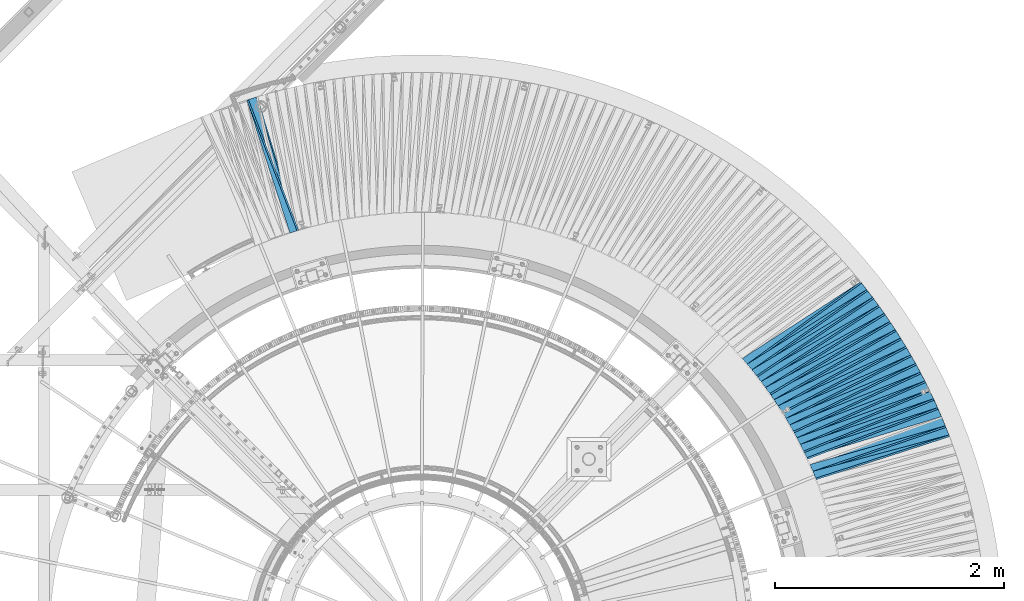
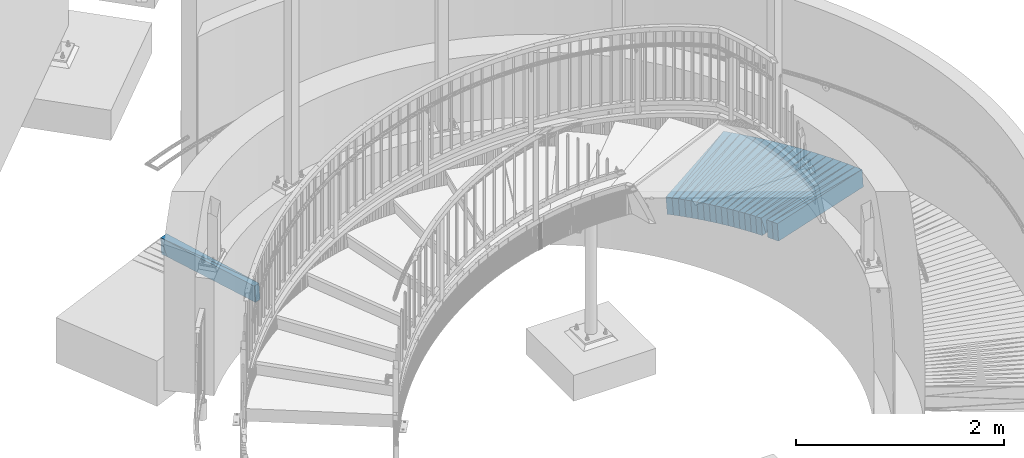
# One storey, part 836 of 975: 38 plates.
"""IFC2X3 building model written with IfcOpenShell, lengths in millimetres."""

from ifc_helpers import new_model, si_unit, frame, origin_with_axes, place, context, subcontext, project, spatial, faceted_brep, material, type_object, element, save


model = new_model("IFC2X3")

# Units and contexts
model_context = context("Model", 3, precision=1e-05, world=origin_with_axes())
body_context = subcontext(model_context, "Body", "Model", "MODEL_VIEW")
ifc_project = project(units=[si_unit("LENGTHUNIT", "METRE", prefix="MILLI"), si_unit("AREAUNIT", "SQUARE_METRE"), si_unit("VOLUMEUNIT", "CUBIC_METRE"), si_unit("MASSUNIT", "GRAM", prefix="KILO"), si_unit("TIMEUNIT", "SECOND"), si_unit("PLANEANGLEUNIT", "RADIAN"), si_unit("SOLIDANGLEUNIT", "STERADIAN"), si_unit("THERMODYNAMICTEMPERATUREUNIT", "DEGREE_CELSIUS"), si_unit("LUMINOUSINTENSITYUNIT", "LUMEN")], contexts=[model_context])

# Site, building, storey
site_placement = place(None, origin_with_axes())
site = spatial("IfcSite", under=ifc_project, at=site_placement, CompositionType="ELEMENT")
building_placement = place(site_placement, origin_with_axes())
building = spatial("IfcBuilding", under=site, at=building_placement, Name="Undefined", CompositionType="ELEMENT")
storey_placement = place(building_placement, origin_with_axes())
storey = spatial("IfcBuildingStorey", under=building, at=storey_placement, Name="Undefined", CompositionType="ELEMENT", Elevation=0.0)

# Plates
ifc_material = material(Name="STEEL/A36")
plate_type_1 = type_object("IfcPlateType", PredefinedType="NOTDEFINED")
plate_1_placement = place(storey_placement, frame((33217.5837224812, 8090.97640843276, -75.0314277608222), z_axis=(0.93169282219722, 0.358603764545342, 0.0578949490032381), x_axis=(0.358981557035001, -0.933335665091, 0.00409609300039937)))
element("IfcPlate", 1, at=plate_1_placement, inside=storey, type_object=plate_type_1, material=ifc_material, Name="SLAB", context=body_context, shape_type="Brep", body=[
    faceted_brep([(-6.82121026329696e-12, -100.000000000011, -1.09139364212751e-10), (4.55844306943254, -99.9999999999961, 86.0408096314204), (4.55844306940435, 99.9999999999868, 86.0408096311367), (5.91171556152403e-12, 100.000000000011, 1.09139364212751e-10), (1220.67553711095, -99.9999999998213, 1.37515598908067e-09), (1220.67553711092, 100.000000000162, 1.0986695997417e-09)], [[[0, 1, 2, 3]], [[1, 4, 5, 2]], [[4, 0, 3, 5]], [[5, 3, 2]], [[4, 1, 0]]]),
])
plate_2_placement = place(storey_placement, frame((39304.8373871946, 5243.97429969041, 351.684010269226), z_axis=(0.3241457711966, -0.944301974475064, 0.0567741139768603), x_axis=(-0.945743967281776, -0.324887014096797, -0.00409590300122032)))
element("IfcPlate", 2, at=plate_2_placement, inside=storey, type_object=plate_type_1, material=ifc_material, Name="SLAB", context=body_context, shape_type="Brep", body=[
    faceted_brep([(-6.82121026329696e-12, -100.000000000011, -1.09139364212751e-10), (-4.5795307158478, -100.000000000003, 85.9765548705582), (-4.57953071649536, 100.000000000011, 85.9765548707792), (5.91171556152403e-12, 100.000000000011, 1.09139364212751e-10), (1220.73205566726, -100.000000000089, 5.53882273379713e-10), (1220.73205566661, 99.9999999999249, 7.73070496506989e-10)], [[[0, 1, 2, 3]], [[1, 4, 5, 2]], [[4, 0, 3, 5]], [[5, 3, 2]], [[4, 1, 0]]]),
])
plate_3_placement = place(storey_placement, frame((39272.7669220496, 5323.70842472493, 346.690466458212), z_axis=(0.340651973808395, -0.938405020893698, 0.0578986139898226), x_axis=(-0.939893015923261, -0.341444550972121, -0.00409111599966596)))
element("IfcPlate", 3, at=plate_3_placement, inside=storey, type_object=plate_type_1, material=ifc_material, Name="SLAB", context=body_context, shape_type="Brep", body=[
    faceted_brep([(-6.82121026329696e-12, -100.000000000011, -1.09139364212751e-10), (-3.0377354618322, -100.00000000001, 86.1432037352588), (-3.03773546206503, 99.999999999996, 86.1432037352679), (5.91171556152403e-12, 100.000000000011, 1.09139364212751e-10), (1222.16040038976, -99.9999999999792, 4.68935468234122e-09), (1222.16040038953, 100.000000000026, 4.69844962935895e-09)], [[[0, 1, 2, 3]], [[1, 4, 5, 2]], [[4, 0, 3, 5]], [[5, 3, 2]], [[4, 1, 0]]]),
])
plate_4_placement = place(storey_placement, frame((39237.8605556861, 5402.24658344831, 341.690705146121), z_axis=(0.356899193856814, -0.932344350483872, 0.0579394299692631), x_axis=(-0.933820393213004, -0.357718742081596, -0.00409570300093424)))
element("IfcPlate", 4, at=plate_4_placement, inside=storey, type_object=plate_type_1, material=ifc_material, Name="SLAB", context=body_context, shape_type="Brep", body=[
    faceted_brep([(-6.82121026329696e-12, -100.000000000011, -1.09139364212751e-10), (-4.62327098886453, -99.999999999995, 85.9701995850792), (-4.62327098847163, 99.9999999999997, 85.9701995849482), (5.91171556152403e-12, 100.000000000011, 1.09139364212751e-10), (1220.79150390594, -100.00000000001, -2.37923813983798e-09), (1220.79150390635, 99.9999999999845, -2.51020537689328e-09)], [[[0, 1, 2, 3]], [[1, 4, 5, 2]], [[4, 0, 3, 5]], [[5, 3, 2]], [[4, 1, 0]]]),
])
plate_5_placement = place(storey_placement, frame((39202.9509047496, 5480.89350006488, 336.69050436779), z_axis=(0.373208382774436, -0.925938713118775, 0.0579051170004576), x_axis=(-0.927398456102163, -0.374052620041207, -0.00409158400045077)))
element("IfcPlate", 5, at=plate_5_placement, inside=storey, type_object=plate_type_1, material=ifc_material, Name="SLAB", context=body_context, shape_type="Brep", body=[
    faceted_brep([(-6.82121026329696e-12, -100.000000000011, -1.09139364212751e-10), (-3.07886791213241, -100.000000000005, 86.1305999755368), (-3.07886791187047, 99.999999999986, 86.1305999753968), (5.91171556152403e-12, 100.000000000011, 1.09139364212751e-10), (1222.02062988063, -99.9999999999855, 4.49108483735472e-09), (1222.02062988089, 100.000000000005, 4.34920366387814e-09)], [[[0, 1, 2, 3]], [[1, 4, 5, 2]], [[4, 0, 3, 5]], [[5, 3, 2]], [[4, 1, 0]]]),
])
plate_6_placement = place(storey_placement, frame((39165.3340698163, 5558.23520251872, 331.690488223701), z_axis=(0.389230944334602, -0.919318205497274, 0.0579077629827445), x_axis=(-0.920765250109163, -0.390096452046248, -0.00401401200047588)))
element("IfcPlate", 6, at=plate_6_placement, inside=storey, type_object=plate_type_1, material=ifc_material, Name="SLAB", context=body_context, shape_type="Brep", body=[
    faceted_brep([(-6.82121026329696e-12, -100.000000000011, -1.09139364212751e-10), (-4.57846403087751, -100.000000000012, 86.0268402097481), (-4.57846403123403, 100.000000000002, 86.02684020997), (5.91171556152403e-12, 100.000000000011, 1.09139364212751e-10), (1220.72375487936, -100.000000000106, -4.74756234325469e-10), (1220.72375487992, 99.9999999999141, -2.58296495303512e-10)], [[[0, 1, 2, 3]], [[1, 4, 5, 2]], [[4, 0, 3, 5]], [[5, 3, 2]], [[4, 1, 0]]]),
])
plate_7_placement = place(storey_placement, frame((39127.6781242042, 5635.68542388389, 326.783982722012), z_axis=(0.405335962729113, -0.912403040192737, 0.0567754310024517), x_axis=(-0.913777206059758, -0.406195939026564, -0.00400958900026222)))
element("IfcPlate", 7, at=plate_7_placement, inside=storey, type_object=plate_type_1, material=ifc_material, Name="SLAB", context=body_context, shape_type="Brep", body=[
    faceted_brep([(-6.82121026329696e-12, -100.000000000011, -1.09139364212751e-10), (-3.0701014992228, -100.000000000012, 86.0881195066431), (-3.07010149981943, 100.000000000009, 86.0881195069851), (5.91171556152403e-12, 100.000000000011, 1.09139364212751e-10), (1222.07031249683, -99.9999999999339, 5.11863618157804e-09), (1222.07031249622, 100.000000000087, 5.46424416825175e-09)], [[[0, 1, 2, 3]], [[1, 4, 5, 2]], [[4, 0, 3, 5]], [[5, 3, 2]], [[4, 1, 0]]]),
])
plate_8_placement = place(storey_placement, frame((39087.3718832034, 5711.6376815379, 321.883919295592), z_axis=(0.421079361007695, -0.905246203413047, 0.0567581090207884), x_axis=(-0.906602014252512, -0.421966836117529, -0.00409597000114084)))
element("IfcPlate", 8, at=plate_8_placement, inside=storey, type_object=plate_type_1, material=ifc_material, Name="SLAB", context=body_context, shape_type="Brep", body=[
    faceted_brep([(-6.82121026329696e-12, -100.000000000011, -1.09139364212751e-10), (-4.61950874349714, -99.9999999999928, 85.9979095460239), (-4.61950874354079, 100.000000000009, 85.9979095460349), (5.91171556152403e-12, 100.000000000011, 1.09139364212751e-10), (1220.71203612899, -99.9999999999177, -1.30785338114947e-09), (1220.71203612895, 100.000000000084, -1.2933014659211e-09)], [[[0, 1, 2, 3]], [[1, 4, 5, 2]], [[4, 0, 3, 5]], [[5, 3, 2]], [[4, 1, 0]]]),
])
plate_9_placement = place(storey_placement, frame((39047.2043368009, 5787.47328674119, 316.89090520201), z_axis=(0.43684924137823, -0.897664230680591, 0.0579799039658314), x_axis=(-0.899067716379963, -0.43779123318502, -0.00400967700169456)))
element("IfcPlate", 9, at=plate_9_placement, inside=storey, type_object=plate_type_1, material=ifc_material, Name="SLAB", context=body_context, shape_type="Brep", body=[
    faceted_brep([(-6.82121026329696e-12, -100.000000000011, -1.09139364212751e-10), (-3.02412271469802, -100.000000000008, 86.0276412962248), (-3.02412271522917, 100.000000000009, 86.0276412965322), (5.91171556152403e-12, 100.000000000011, 1.09139364212751e-10), (1222.04370117421, -100.000000000086, -3.67253960575908e-09), (1222.04370117367, 99.9999999999309, -3.36331140715629e-09)], [[[0, 1, 2, 3]], [[1, 4, 5, 2]], [[4, 0, 3, 5]], [[5, 3, 2]], [[4, 1, 0]]]),
])
plate_10_placement = place(storey_placement, frame((39004.2425576214, 5862.13925037848, 311.983785554002), z_axis=(0.452393196076373, -0.890012124948215, 0.0567345889997196), x_axis=(-0.891335017694484, -0.453326714844618, -0.0040958319985961)))
element("IfcPlate", 10, at=plate_10_placement, inside=storey, type_object=plate_type_1, material=ifc_material, Name="SLAB", context=body_context, shape_type="Brep", body=[
    faceted_brep([(-6.82121026329696e-12, -100.000000000011, -1.09139364212751e-10), (-4.57463502939936, -99.9999999999849, 86.0368118288479), (-4.5746350287518, 99.9999999999941, 86.036811828586), (5.91171556152403e-12, 100.000000000011, 1.09139364212751e-10), (1220.75317382871, -100.000000000028, -5.38420863449574e-10), (1220.75317382935, 99.9999999999507, -7.98536348156631e-10)], [[[0, 1, 2, 3]], [[1, 4, 5, 2]], [[4, 0, 3, 5]], [[5, 3, 2]], [[4, 1, 0]]]),
])
plate_11_placement = place(storey_placement, frame((38961.3826333786, 5936.58654527266, 306.99058968587), z_axis=(0.467883524941811, -0.881890185730348, 0.0579198359849058), x_axis=(-0.883254491691378, -0.468876063836167, -0.00409141399857039)))
element("IfcPlate", 11, at=plate_11_placement, inside=storey, type_object=plate_type_1, material=ifc_material, Name="SLAB", context=body_context, shape_type="Brep", body=[
    faceted_brep([(-6.82121026329696e-12, -100.000000000011, -1.09139364212751e-10), (-3.06913352011179, -100.000000000001, 86.1094131469526), (-3.06913352039555, 100.000000000005, 86.1094131471145), (5.91171556152403e-12, 100.000000000011, 1.09139364212751e-10), (1222.07128906666, -100.000000000093, -1.39516487251967e-09), (1222.07128906639, 99.9999999999133, -1.23509380500764e-09)], [[[0, 1, 2, 3]], [[1, 4, 5, 2]], [[4, 0, 3, 5]], [[5, 3, 2]], [[4, 1, 0]]]),
])
plate_12_placement = place(storey_placement, frame((38915.861182674, 6009.53732260342, 301.990549499056), z_axis=(0.48319325767782, -0.873595868993539, 0.0579183339895024), x_axis=(-0.874945036402083, -0.484205609222519, -0.00401388500184458)))
element("IfcPlate", 12, at=plate_12_placement, inside=storey, type_object=plate_type_1, material=ifc_material, Name="SLAB", context=body_context, shape_type="Brep", body=[
    faceted_brep([(-6.82121026329696e-12, -100.000000000011, -1.09139364212751e-10), (-4.61897420861351, -100.000000000009, 86.0083465574935), (-4.61897420915921, 100.000000000007, 86.0083465577081), (5.91171556152403e-12, 100.000000000011, 1.09139364212751e-10), (1220.76245117532, -100.000000000111, -3.84352460969239e-09), (1220.76245117479, 99.9999999999047, -3.62524588126689e-09)], [[[0, 1, 2, 3]], [[1, 4, 5, 2]], [[4, 0, 3, 5]], [[5, 3, 2]], [[4, 1, 0]]]),
])
plate_13_placement = place(storey_placement, frame((38870.2934492541, 6082.7004527467, 297.083744262738), z_axis=(0.498478531507273, -0.865044003722468, 0.0567276409711753), x_axis=(-0.866315894896196, -0.49947975994015, -0.00409141299950977)))
element("IfcPlate", 13, at=plate_13_placement, inside=storey, type_object=plate_type_1, material=ifc_material, Name="SLAB", context=body_context, shape_type="Brep", body=[
    faceted_brep([(-6.82121026329696e-12, -100.000000000011, -1.09139364212751e-10), (-3.06203031529003, -100.000000000005, 86.1567993163808), (-3.06203031592304, 100.00000000002, 86.15679931671), (5.91171556152403e-12, 100.000000000011, 1.09139364212751e-10), (1222.07153320566, -99.9999999999113, -3.09228198602796e-10), (1222.07153320539, 100.000000000073, -4.69299266114831e-10)], [[[0, 1, 2, 3]], [[1, 4, 5, 2]], [[4, 0, 3, 5]], [[5, 3, 2]], [[4, 1, 0]]]),
])
plate_14_placement = place(storey_placement, frame((38822.3382766663, 6153.85139697975, 292.090799755722), z_axis=(0.513379285667194, -0.8562025717769, 0.0579557169782551), x_axis=(-0.857514643792092, -0.514443251875272, -0.00409588599900694)))
element("IfcPlate", 14, at=plate_14_placement, inside=storey, type_object=plate_type_1, material=ifc_material, Name="SLAB", context=body_context, shape_type="Brep", body=[
    faceted_brep([(-6.82121026329696e-12, -100.000000000011, -1.09139364212751e-10), (-4.63857412335346, -100.000000000003, 85.9449462890298), (-4.63857412314246, 99.9999999999876, 85.9449462888588), (5.91171556152403e-12, 100.000000000011, 1.09139364212751e-10), (1220.73718261951, -100.000000000088, -1.3405951904133e-09), (1220.73718261972, 99.9999999999017, -1.50976120494306e-09)], [[[0, 1, 2, 3]], [[1, 4, 5, 2]], [[4, 0, 3, 5]], [[5, 3, 2]], [[4, 1, 0]]]),
])
plate_15_placement = place(storey_placement, frame((38774.312485556, 6225.20812180776, 287.090616019387), z_axis=(0.528302141677085, -0.847077890916715, 0.0579300769850582), x_axis=(-0.848372852094266, -0.529384005058822, -0.00400986500044553)))
element("IfcPlate", 15, at=plate_15_placement, inside=storey, type_object=plate_type_1, material=ifc_material, Name="SLAB", context=body_context, shape_type="Brep", body=[
    faceted_brep([(-6.82121026329696e-12, -100.000000000011, -1.09139364212751e-10), (-3.08170390122541, -99.9999999999985, 86.097633361831), (-3.08170390122541, 99.9999999999999, 86.0976333617382), (5.91171556152403e-12, 100.000000000011, 1.09139364212751e-10), (1221.98632812593, -100.00000000001, 2.18824425246567e-09), (1221.98632812593, 99.9999999999889, 2.09547579288483e-09)], [[[0, 1, 2, 3]], [[1, 4, 5, 2]], [[4, 0, 3, 5]], [[5, 3, 2]], [[4, 1, 0]]]),
])
plate_16_placement = place(storey_placement, frame((38723.8369335262, 6294.97141798948, 282.183894539567), z_axis=(0.542977314792006, -0.837827337851491, 0.0567537449861), x_axis=(-0.839046225811829, -0.544044715877989, -0.0040961049990814)))
element("IfcPlate", 16, at=plate_16_placement, inside=storey, type_object=plate_type_1, material=ifc_material, Name="SLAB", context=body_context, shape_type="Brep", body=[
    faceted_brep([(-6.82121026329696e-12, -100.000000000011, -1.09139364212751e-10), (-4.52639293691027, -99.9999999999964, 86.0112304688282), (-4.52639293648099, 99.9999999999903, 86.0112304685863), (5.91171556152403e-12, 100.000000000011, 1.09139364212751e-10), (1220.67175292795, -99.9999999999477, 3.03225533571094e-09), (1220.67175292839, 100.000000000039, 2.7885107556358e-09)], [[[0, 1, 2, 3]], [[1, 4, 5, 2]], [[4, 0, 3, 5]], [[5, 3, 2]], [[4, 1, 0]]]),
])
plate_17_placement = place(storey_placement, frame((38673.4818827135, 6364.53363342695, 277.190706200143), z_axis=(0.557543327411047, -0.828123424471904, 0.05793989903636), x_axis=(-0.829377363387286, -0.55867382926088, -0.00409165000191065)))
element("IfcPlate", 17, at=plate_17_placement, inside=storey, type_object=plate_type_1, material=ifc_material, Name="SLAB", context=body_context, shape_type="Brep", body=[
    faceted_brep([(-6.82121026329696e-12, -100.000000000011, -1.09139364212751e-10), (-3.02031660069042, -99.9999999999974, 86.0830307006891), (-3.02031660120701, 100.000000000018, 86.0830307009583), (5.91171556152403e-12, 100.000000000011, 1.09139364212751e-10), (1222.00109863065, -100.000000000075, -2.01544025912881e-09), (1222.00109863035, 99.9999999999072, -2.20825313590467e-09)], [[[0, 1, 2, 3]], [[1, 4, 5, 2]], [[4, 0, 3, 5]], [[5, 3, 2]], [[4, 1, 0]]]),
])
plate_18_placement = place(storey_placement, frame((38620.6556532324, 6432.28958806128, 272.190825947744), z_axis=(0.571785846111488, -0.818352548661649, 0.0579659579887518), x_axis=(-0.81959076206308, -0.572935311044095, -0.00401398800030893)))
element("IfcPlate", 18, at=plate_18_placement, inside=storey, type_object=plate_type_1, material=ifc_material, Name="SLAB", context=body_context, shape_type="Brep", body=[
    faceted_brep([(-6.82121026329696e-12, -100.000000000011, -1.09139364212751e-10), (-4.58870077134634, -99.9999999999911, 85.9397659302813), (-4.58870077160827, 100.000000000009, 85.939765930354), (5.91171556152403e-12, 100.000000000011, 1.09139364212751e-10), (1220.73120116976, -99.9999999999685, -2.50656739808619e-09), (1220.73120116951, 100.000000000031, -2.44108377955854e-09)], [[[0, 1, 2, 3]], [[1, 4, 5, 2]], [[4, 0, 3, 5]], [[5, 3, 2]], [[4, 1, 0]]]),
])
plate_19_placement = place(storey_placement, frame((38567.6620937427, 6500.25340811913, 267.283776896806), z_axis=(0.586106887899127, -0.808244627507758, 0.0567392109748218), x_axis=(-0.809408476541484, -0.587232355667341, -0.00400980799772848)))
element("IfcPlate", 19, at=plate_19_placement, inside=storey, type_object=plate_type_1, material=ifc_material, Name="SLAB", context=body_context, shape_type="Brep", body=[
    faceted_brep([(-6.82121026329696e-12, -100.000000000011, -1.09139364212751e-10), (-3.10394358630583, -99.9999999999993, 86.1406707763017), (-3.1039435868297, 100.000000000019, 86.1406707766764), (5.91171556152403e-12, 100.000000000011, 1.09139364212751e-10), (1222.00354003799, -99.9999999999427, -1.37515598908067e-09), (1222.00354003746, 100.000000000076, -1.00408215075731e-09)], [[[0, 1, 2, 3]], [[1, 4, 5, 2]], [[4, 0, 3, 5]], [[5, 3, 2]], [[4, 1, 0]]]),
])
plate_type_2 = type_object("IfcPlateType", PredefinedType="NOTDEFINED")
plate_20_placement = place(storey_placement, frame((33219.3539741438, 8091.65784862846, -74.9033204803397), z_axis=(0.948254012582335, 0.308041456766694, 0.0769726479637683), x_axis=(0.308958072093269, -0.95107565928711, 0.0)))
element("IfcPlate", 20, at=plate_20_placement, inside=storey, type_object=plate_type_2, material=ifc_material, Name="SLAB", context=body_context, shape_type="Brep", body=[
    faceted_brep([(-6.82121026329696e-12, -100.000000000011, -1.09139364212751e-10), (1218.94592285101, -100.000000000156, 64.9581375101843), (1218.94592285111, 99.9999999998613, 64.9581375104171), (5.91171556152403e-12, 100.000000000011, 1.09139364212751e-10), (1218.93566894475, -100.000000000158, -1.96450855582952e-09), (1218.93566894485, 99.9999999998604, -1.72440195456147e-09)], [[[0, 1, 2, 3]], [[1, 4, 5, 2]], [[4, 0, 3, 5]], [[5, 3, 2]], [[4, 1, 0]]]),
])
plate_21_placement = place(storey_placement, frame((39337.5588873171, 5162.31721505765, 356.718951920133), z_axis=(0.256647528359579, -0.963464733736902, 0.0766012599909452), x_axis=(-0.966112963660343, -0.257993762909296, -0.00805976099716641)))
element("IfcPlate", 21, at=plate_21_placement, inside=storey, type_object=plate_type_2, material=ifc_material, Name="SLAB", context=body_context, shape_type="Brep", body=[
    faceted_brep([(-6.82121026329696e-12, -100.000000000011, -1.09139364212751e-10), (1220.28710937338, -99.9999999999648, 64.4274215697833), (1220.28710937271, 100.000000000045, 64.4274215698779), (5.91171556152403e-12, 100.000000000011, 1.09139364212751e-10), (1228.32421874839, -99.9999999999676, 2.85581336356699e-09), (1228.32421874773, 100.000000000042, 2.94858182314783e-09)], [[[0, 1, 2, 3]], [[1, 4, 5, 2]], [[4, 0, 3, 5]], [[5, 3, 2]], [[4, 1, 0]]]),
])
plate_22_placement = place(storey_placement, frame((39203.6029312498, 5479.27563956028, 336.806984948786), z_axis=(0.323276117056149, -0.943325735067035, 0.0750273930063952), x_axis=(-0.945764545078944, -0.324752929027108, -0.00805979900067276)))
element("IfcPlate", 22, at=plate_22_placement, inside=storey, type_object=plate_type_2, material=ifc_material, Name="SLAB", context=body_context, shape_type="Brep", body=[
    faceted_brep([(-6.82121026329696e-12, -100.000000000011, -1.09139364212751e-10), (1220.3198242223, -100.000000000114, 64.450233458746), (1220.3198242224, 99.9999999998832, 64.4502334586932), (5.91171556152403e-12, 100.000000000011, 1.09139364212751e-10), (1228.3183593787, -100.000000000122, -2.07364792004228e-09), (1228.31835937881, 99.9999999998759, -2.12548911804333e-09)], [[[0, 1, 2, 3]], [[1, 4, 5, 2]], [[4, 0, 3, 5]], [[5, 3, 2]], [[4, 1, 0]]]),
])
plate_23_placement = place(storey_placement, frame((39128.493786465, 5633.84918408846, 326.918551550565), z_axis=(0.355940269861473, -0.931368215415939, 0.0765491450237798), x_axis=(-0.933857657129516, -0.357554078049587, -0.00805962100111777)))
element("IfcPlate", 23, at=plate_23_placement, inside=storey, type_object=plate_type_2, material=ifc_material, Name="SLAB", context=body_context, shape_type="Brep", body=[
    faceted_brep([(-6.82121026329696e-12, -100.000000000011, -1.09139364212751e-10), (1220.36816406491, -100.000000000122, 64.4775924670357), (1220.36816406523, 99.9999999998687, 64.4775924669648), (5.91171556152403e-12, 100.000000000011, 1.09139364212751e-10), (1228.34570312729, -100.00000000012, 1.88265403266996e-09), (1228.34570312761, 99.9999999998707, 1.81353243533522e-09)], [[[0, 1, 2, 3]], [[1, 4, 5, 2]], [[4, 0, 3, 5]], [[5, 3, 2]], [[4, 1, 0]]]),
])
plate_24_placement = place(storey_placement, frame((39048.0304193133, 5785.77563812598, 317.018487387102), z_axis=(0.3881750576626, -0.918401672762374, 0.0765407870086983), x_axis=(-0.920832810021308, -0.389874311009023, -0.00805962800018652)))
element("IfcPlate", 24, at=plate_24_placement, inside=storey, type_object=plate_type_2, material=ifc_material, Name="SLAB", context=body_context, shape_type="Brep", body=[
    faceted_brep([(-6.82121026329696e-12, -100.000000000011, -1.09139364212751e-10), (1220.34130859381, -99.9999999999665, 64.4819107060684), (1220.34130859397, 100.000000000023, 64.4819107059502), (5.91171556152403e-12, 100.000000000011, 1.09139364212751e-10), (1228.34460449222, -99.9999999999643, 5.78438630327582e-10), (1228.34460449237, 100.000000000025, 4.58385329693556e-10)], [[[0, 1, 2, 3]], [[1, 4, 5, 2]], [[4, 0, 3, 5]], [[5, 3, 2]], [[4, 1, 0]]]),
])
plate_25_placement = place(storey_placement, frame((38962.2054432622, 5935.03553681454, 307.107961201493), z_axis=(0.420122178713842, -0.904349914482573, 0.0751570830201477), x_axis=(-0.906629396047168, -0.421850905021947, -0.00805929000041928)))
element("IfcPlate", 25, at=plate_25_placement, inside=storey, type_object=plate_type_2, material=ifc_material, Name="SLAB", context=body_context, shape_type="Brep", body=[
    faceted_brep([(-6.82121026329696e-12, -100.000000000011, -1.09139364212751e-10), (1220.37658691661, -100.000000000164, 64.3368377668703), (1220.37658691619, 99.9999999998425, 64.3368377669703), (5.91171556152403e-12, 100.000000000011, 1.09139364212751e-10), (1228.3961181667, -100.000000000169, 1.32240529637784e-09), (1228.3961181663, 99.9999999998372, 1.42244971357286e-09)], [[[0, 1, 2, 3]], [[1, 4, 5, 2]], [[4, 0, 3, 5]], [[5, 3, 2]], [[4, 1, 0]]]),
])
plate_26_placement = place(storey_placement, frame((38916.7808520786, 6007.87444303917, 302.118961634576), z_axis=(0.435738545451771, -0.896807666467731, 0.0766024110082586), x_axis=(-0.899150462316322, -0.437565388153938, -0.00806084400283583)))
element("IfcPlate", 26, at=plate_26_placement, inside=storey, type_object=plate_type_2, material=ifc_material, Name="SLAB", context=body_context, shape_type="Brep", body=[
    faceted_brep([(-6.82121026329696e-12, -100.000000000011, -1.09139364212751e-10), (1219.06701660497, -100.000000000106, 64.3153228748797), (1219.06701660489, 99.9999999998971, 64.3153228748724), (5.91171556152403e-12, 100.000000000011, 1.09139364212751e-10), (1228.15930176112, -100.000000000102, -9.31322574615479e-10), (1228.15930176102, 99.9999999999014, -9.36779542826116e-10)], [[[0, 1, 2, 3]], [[1, 4, 5, 2]], [[4, 0, 3, 5]], [[5, 3, 2]], [[4, 1, 0]]]),
])
plate_27_placement = place(storey_placement, frame((38871.3044737875, 6080.94578343577, 297.219439056729), z_axis=(0.45140260096793, -0.889021674307709, 0.0766560790186028), x_axis=(-0.891332178179424, -0.453277703091244, -0.00814076300163872)))
element("IfcPlate", 27, at=plate_27_placement, inside=storey, type_object=plate_type_2, material=ifc_material, Name="SLAB", context=body_context, shape_type="Brep", body=[
    faceted_brep([(-6.82121026329696e-12, -100.000000000011, -1.09139364212751e-10), (1220.37475585972, -100.000000000081, 64.3756179802294), (1220.37475585983, 99.9999999999138, 64.3756179802167), (5.91171556152403e-12, 100.000000000011, 1.09139364212751e-10), (1228.38598632866, -100.000000000088, -4.12910594604909e-09), (1228.38598632877, 99.9999999999061, -4.14365786127746e-09)], [[[0, 1, 2, 3]], [[1, 4, 5, 2]], [[4, 0, 3, 5]], [[5, 3, 2]], [[4, 1, 0]]]),
])
plate_28_placement = place(storey_placement, frame((38775.3175686573, 6223.59643737721, 287.218984801113), z_axis=(0.482089278223095, -0.872766595866657, 0.0766054630014262), x_axis=(-0.875010752041325, -0.484036375022861, -0.00806048800038067)))
element("IfcPlate", 28, at=plate_28_placement, inside=storey, type_object=plate_type_2, material=ifc_material, Name="SLAB", context=body_context, shape_type="Brep", body=[
    faceted_brep([(-6.82121026329696e-12, -100.000000000011, -1.09139364212751e-10), (1220.28625488043, -99.9999999999266, 64.4353866588444), (1220.28625488027, 100.000000000072, 64.4353866588608), (5.91171556152403e-12, 100.000000000011, 1.09139364212751e-10), (1228.21350097414, -99.9999999999245, 1.43700162880123e-09), (1228.21350097399, 100.000000000074, 1.44973455462605e-09)], [[[0, 1, 2, 3]], [[1, 4, 5, 2]], [[4, 0, 3, 5]], [[5, 3, 2]], [[4, 1, 0]]]),
])
plate_29_placement = place(storey_placement, frame((38674.454482571, 6363.08891152754, 277.30704318969), z_axis=(0.51232359539911, -0.855508188862592, 0.0750351410099067), x_axis=(-0.857587166952236, -0.514275501971356, -0.00805972399955107)))
element("IfcPlate", 29, at=plate_29_placement, inside=storey, type_object=plate_type_2, material=ifc_material, Name="SLAB", context=body_context, shape_type="Brep", body=[
    faceted_brep([(-6.82121026329696e-12, -100.000000000011, -1.09139364212751e-10), (1220.30078125048, -99.9999999999889, 64.4402999877511), (1220.30078125046, 100.000000000006, 64.4402999876729), (5.91171556152403e-12, 100.000000000011, 1.09139364212751e-10), (1228.3299560553, -99.9999999999969, 7.89441401138902e-10), (1228.32995605528, 99.9999999999982, 7.13043846189976e-10)], [[[0, 1, 2, 3]], [[1, 4, 5, 2]], [[4, 0, 3, 5]], [[5, 3, 2]], [[4, 1, 0]]]),
])
plate_30_placement = place(storey_placement, frame((38568.8519471672, 6498.61245251818, 267.419637304542), z_axis=(0.541805561734343, -0.836997797249345, 0.0766904210020899), x_axis=(-0.83910577588888, -0.543908574927972, -0.00805971399893268)))
element("IfcPlate", 30, at=plate_30_placement, inside=storey, type_object=plate_type_2, material=ifc_material, Name="SLAB", context=body_context, shape_type="Brep", body=[
    faceted_brep([(-6.82121026329696e-12, -100.000000000011, -1.09139364212751e-10), (1220.30786132449, -99.9999999998267, 64.3539581317473), (1220.30786132425, 100.00000000019, 64.3539581319183), (5.91171556152403e-12, 100.000000000011, 1.09139364212751e-10), (1228.33142089473, -99.9999999998265, 3.07773007079959e-09), (1228.33142089449, 100.00000000019, 3.24689608532935e-09)], [[[0, 1, 2, 3]], [[1, 4, 5, 2]], [[4, 0, 3, 5]], [[5, 3, 2]], [[4, 1, 0]]]),
])
plate_type_3 = type_object("IfcPlateType", PredefinedType="NOTDEFINED")
plate_31_placement = place(storey_placement, frame((39305.4926105564, 5242.06524341369, 351.819279950205), z_axis=(0.273388274786019, -0.958846122725294, 0.0766352669741168), x_axis=(-0.961470567865419, -0.274787294961538, -0.00814184599886039)))
element("IfcPlate", 31, at=plate_31_placement, inside=storey, type_object=plate_type_3, material=ifc_material, Name="SLAB", context=body_context, shape_type="Brep", body=[
    faceted_brep([(-6.82121026329696e-12, -100.000000000011, -1.09139364212751e-10), (1219.03906250356, -100.00000000013, 64.2684326158078), (1219.03906250394, 99.9999999998537, 64.2684326156332), (5.91171556152403e-12, 100.000000000011, 1.09139364212751e-10), (1228.22277832386, -100.000000000129, -3.22324922308326e-09), (1228.22277832426, 99.999999999855, -3.39787220582366e-09)], [[[0, 1, 2, 3]], [[1, 4, 5, 2]], [[4, 0, 3, 5]], [[5, 3, 2]], [[4, 1, 0]]]),
])
plate_32_placement = place(storey_placement, frame((39238.5406952285, 5400.46961464034, 341.819345327603), z_axis=(0.306703657202241, -0.948714187436615, 0.0766437030371936), x_axis=(-0.95128875405282, -0.308193780017113, -0.00814250400045212)))
element("IfcPlate", 32, at=plate_32_placement, inside=storey, type_object=plate_type_3, material=ifc_material, Name="SLAB", context=body_context, shape_type="Brep", body=[
    faceted_brep([(-6.82121026329696e-12, -100.000000000011, -1.09139364212751e-10), (1219.09814453375, -100.000000000107, 64.2780990592482), (1219.09814453369, 99.9999999998919, 64.2780990591991), (5.91171556152403e-12, 100.000000000011, 1.09139364212751e-10), (1228.1234130885, -100.000000000112, -2.07364792004228e-10), (1228.12341308843, 99.9999999998871, -2.55568011198193e-10)], [[[0, 1, 2, 3]], [[1, 4, 5, 2]], [[4, 0, 3, 5]], [[5, 3, 2]], [[4, 1, 0]]]),
])
plate_33_placement = place(storey_placement, frame((39166.0188304847, 5556.61771769852, 331.807892511947), z_axis=(0.339723751013211, -0.937517612852466, 0.0751564939903879), x_axis=(-0.939941673761075, -0.34124181891326, -0.00797940799797174)))
element("IfcPlate", 33, at=plate_33_placement, inside=storey, type_object=plate_type_3, material=ifc_material, Name="SLAB", context=body_context, shape_type="Brep", body=[
    faceted_brep([(-6.82121026329696e-12, -100.000000000011, -1.09139364212751e-10), (1219.03283691029, -99.9999999997983, 64.2281265277934), (1219.03283691064, 100.000000000181, 64.2281265275842), (5.91171556152403e-12, 100.000000000011, 1.09139364212751e-10), (1228.16125487908, -99.9999999997989, 6.63931132294238e-11), (1228.16125487944, 100.000000000181, -1.41881173476577e-10)], [[[0, 1, 2, 3]], [[1, 4, 5, 2]], [[4, 0, 3, 5]], [[5, 3, 2]], [[4, 1, 0]]]),
])
plate_34_placement = place(storey_placement, frame((39088.1627104439, 5709.93737096652, 322.008213226435), z_axis=(0.372225769617202, -0.925091560940713, 0.0751902939823786), x_axis=(-0.927460524078921, -0.373834176031812, -0.00806133400068598)))
element("IfcPlate", 34, at=plate_34_placement, inside=storey, type_object=plate_type_3, material=ifc_material, Name="SLAB", context=body_context, shape_type="Brep", body=[
    faceted_brep([(-6.82121026329696e-12, -100.000000000011, -1.09139364212751e-10), (1219.02282714895, -100.000000000043, 64.1964492795105), (1219.02282714833, 99.9999999999915, 64.1964492798343), (5.91171556152403e-12, 100.000000000011, 1.09139364212751e-10), (1228.08459472685, -100.000000000037, -2.38287611864507e-10), (1228.08459472624, 99.9999999999973, 8.54925019666553e-11)], [[[0, 1, 2, 3]], [[1, 4, 5, 2]], [[4, 0, 3, 5]], [[5, 3, 2]], [[4, 1, 0]]]),
])
plate_35_placement = place(storey_placement, frame((39005.1583821266, 5860.33732460642, 312.119201406155), z_axis=(0.404140595177844, -0.911481753950267, 0.0766250060035428), x_axis=(-0.91388531350085, -0.405890795222446, -0.0081422430044623)))
element("IfcPlate", 35, at=plate_35_placement, inside=storey, type_object=plate_type_3, material=ifc_material, Name="SLAB", context=body_context, shape_type="Brep", body=[
    faceted_brep([(-6.82121026329696e-12, -100.000000000011, -1.09139364212751e-10), (1219.05932617196, -100.000000000062, 64.2854919429155), (1219.05932617153, 99.9999999999634, 64.2854919431356), (5.91171556152403e-12, 100.000000000011, 1.09139364212751e-10), (1228.16284179705, -100.000000000065, -3.06863512378186e-09), (1228.16284179661, 99.9999999999599, -2.84489942714572e-09)], [[[0, 1, 2, 3]], [[1, 4, 5, 2]], [[4, 0, 3, 5]], [[5, 3, 2]], [[4, 1, 0]]]),
])
plate_36_placement = place(storey_placement, frame((38823.2360453546, 6152.35399615906, 292.207490239229), z_axis=(0.466852336156721, -0.881141154281265, 0.0750943570242971), x_axis=(-0.883323070371363, -0.468695390197048, -0.00806130000338912)))
element("IfcPlate", 36, at=plate_36_placement, inside=storey, type_object=plate_type_3, material=ifc_material, Name="SLAB", context=body_context, shape_type="Brep", body=[
    faceted_brep([(-6.82121026329696e-12, -100.000000000011, -1.09139364212751e-10), (1219.04357910591, -100.000000000212, 64.2801513652994), (1219.04357910544, 99.999999999815, 64.2801513655359), (5.91171556152403e-12, 100.000000000011, 1.09139364212751e-10), (1228.08972168394, -100.000000000207, -2.97040969599038e-09), (1228.08972168346, 99.9999999998205, -2.73576006293297e-09)], [[[0, 1, 2, 3]], [[1, 4, 5, 2]], [[4, 0, 3, 5]], [[5, 3, 2]], [[4, 1, 0]]]),
])
plate_37_placement = place(storey_placement, frame((38724.9377634098, 6293.27265518234, 282.319577452425), z_axis=(0.49725568695314, -0.864209410191934, 0.0766738360098792), x_axis=(-0.866419747123098, -0.499249950070932, -0.00814304300115694)))
element("IfcPlate", 37, at=plate_37_placement, inside=storey, type_object=plate_type_3, material=ifc_material, Name="SLAB", context=body_context, shape_type="Brep", body=[
    faceted_brep([(-6.82121026329696e-12, -100.000000000011, -1.09139364212751e-10), (1218.97973632769, -99.9999999999379, 64.2488250740516), (1218.97973632775, 100.000000000053, 64.2488250739189), (5.91171556152403e-12, 100.000000000011, 1.09139364212751e-10), (1228.04223632776, -99.9999999999388, 2.96495272777975e-10), (1228.04223632781, 100.000000000052, 1.60071067512035e-10)], [[[0, 1, 2, 3]], [[1, 4, 5, 2]], [[4, 0, 3, 5]], [[5, 3, 2]], [[4, 1, 0]]]),
])
plate_38_placement = place(storey_placement, frame((38621.6550084702, 6430.85918139169, 272.307460255871), z_axis=(0.527110227161597, -0.846472051102923, 0.0750991020136774), x_axis=(-0.848524346719532, -0.529096171825116, -0.00797959799736245)))
element("IfcPlate", 38, at=plate_38_placement, inside=storey, type_object=plate_type_3, material=ifc_material, Name="SLAB", context=body_context, shape_type="Brep", body=[
    faceted_brep([(-6.82121026329696e-12, -100.000000000011, -1.09139364212751e-10), (1219.03759765899, -100.000000000215, 64.2807846045853), (1219.03759765867, 99.9999999998031, 64.2807846048036), (5.91171556152403e-12, 100.000000000011, 1.09139364212751e-10), (1228.13208008069, -100.000000000206, -7.91260390542448e-10), (1228.13208008037, 99.9999999998117, -5.67524693906307e-10)], [[[0, 1, 2, 3]], [[1, 4, 5, 2]], [[4, 0, 3, 5]], [[5, 3, 2]], [[4, 1, 0]]]),
])

save(model, "model.ifc")
